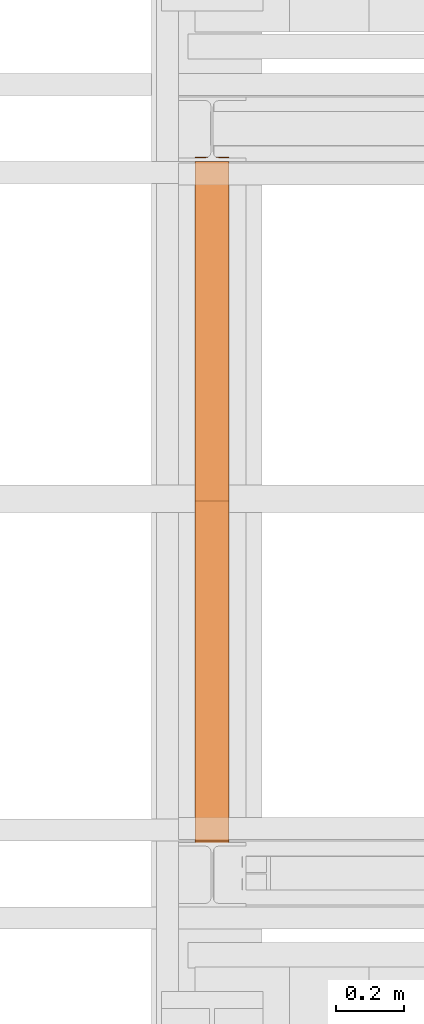
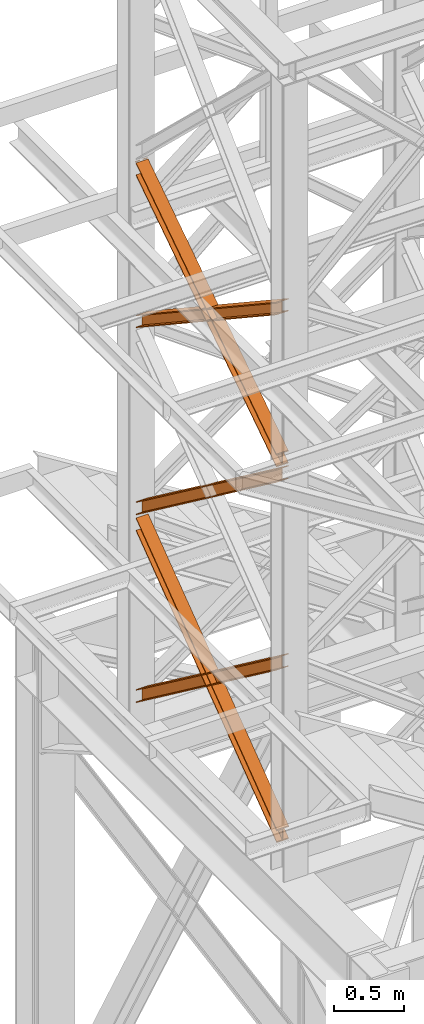
# One storey, part 95 of 208: 5 proxies.
"""IFC2X3 building model written with IfcOpenShell, lengths in millimetres."""

import ifcopenshell
import ifcopenshell.guid

model = None  # the IFC model being written
_history = None  # IfcOwnerHistory: only IFC2X3 demands one
_inside = {}  # id of a spatial element -> (the spatial element, [elements in it])
_under = {}  # id of a project, library or spatial element -> (it, [spatial elements below it])
_declared = {}  # id of a project -> (the project, [libraries it declares])
_typed = {}  # id of a type object -> (the type object, [elements of that type])
_made_of = {}  # id of a material, layer set ... -> (it, [elements and type objects made of it])


def new_model(schema):
    """Start an empty IFC model of exactly this schema.

    Asked for "IFC4X3", IfcOpenShell would pick the latest addendum, in which some entities
    have other attributes; the version numbers below select the first issue.
    IFC2X3 requires an IfcOwnerHistory on every rooted entity: one is made here for all.
    """
    global model, _history
    if schema == "IFC4X3":
        model = ifcopenshell.file(schema_version=(4, 3, 0, 0))
    else:
        model = ifcopenshell.file(schema=schema)
    _inside.clear()
    _under.clear()
    _declared.clear()
    _typed.clear()
    _made_of.clear()
    _history = None
    if model.schema == "IFC2X3":
        org = make("IfcOrganization", Name="unknown")
        user = make(
            "IfcPersonAndOrganization",
            ThePerson=make("IfcPerson", FamilyName="unknown"),
            TheOrganization=org,
        )
        app = make(
            "IfcApplication",
            ApplicationDeveloper=org,
            Version="unknown",
            ApplicationFullName="unknown",
            ApplicationIdentifier="unknown",
        )
        _history = make(
            "IfcOwnerHistory",
            OwningUser=user,
            OwningApplication=app,
            ChangeAction="ADDED",
            CreationDate=0,
        )
    return model


def make(cls, **values):
    """One entity of the class cls with the attributes given. An attribute that is None is left unset."""
    return model.create_entity(
        cls, **{name: value for name, value in values.items() if value is not None}
    )


def entity(cls, *values):
    """Any entity or typed value of the class cls, its attributes in the order of the schema. None: left unset."""
    e = model.create_entity(cls)
    for i, value in enumerate(values):
        if value is not None:
            e[i] = value
    return e


def rooted(cls, **values):
    """An entity with a GlobalId (a new one), such as an element, a storey or a relation."""
    return make(cls, GlobalId=ifcopenshell.guid.new(), OwnerHistory=_history, **values)


def si_unit(unit_type, name, prefix=None):
    """IfcSIUnit, for example si_unit("LENGTHUNIT", "METRE", prefix="MILLI")."""
    return make("IfcSIUnit", UnitType=unit_type, Prefix=prefix, Name=name)


def converted_unit(unit_type, name, factor, base, dimensions=None, offset=None):
    """IfcConversionBasedUnit, such as the inch: factor (a typed value) times the base unit."""
    return make(
        "IfcConversionBasedUnit"
        if offset is None
        else "IfcConversionBasedUnitWithOffset",
        ConversionOffset=offset,
        Dimensions=None
        if dimensions is None
        else entity("IfcDimensionalExponents", *dimensions),
        UnitType=unit_type,
        Name=name,
        ConversionFactor=make(
            "IfcMeasureWithUnit", ValueComponent=factor, UnitComponent=base
        ),
    )


def assignment(units):
    """IfcUnitAssignment: the units of a project."""
    return None if units is None else make("IfcUnitAssignment", Units=units)


def point(xyz):
    """IfcCartesianPoint."""
    return None if xyz is None else make("IfcCartesianPoint", Coordinates=xyz)


def direction(xyz):
    """IfcDirection."""
    return None if xyz is None else make("IfcDirection", DirectionRatios=xyz)


def frame(location, z_axis=None, x_axis=None):
    """IfcAxis2Placement3D, a coordinate frame: its origin and axes. An axis left out is left unset."""
    return make(
        "IfcAxis2Placement3D",
        Location=point(location),
        Axis=direction(z_axis),
        RefDirection=direction(x_axis),
    )


def origin():
    """The frame at (0, 0, 0) with its axes left unset."""
    return frame((0.0, 0.0, 0.0))


def origin_with_axes():
    """The frame at (0, 0, 0) with the z axis (0, 0, 1) and the x axis (1, 0, 0) written out."""
    return frame((0.0, 0.0, 0.0), z_axis=(0.0, 0.0, 1.0), x_axis=(1.0, 0.0, 0.0))


def place(relative_to, where):
    """IfcLocalPlacement: puts the frame where relative to a parent placement (None: the world)."""
    return make(
        "IfcLocalPlacement", PlacementRelTo=relative_to, RelativePlacement=where
    )


def context(
    kind, dimensions, precision=None, world=None, true_north=None, identifier=None
):
    """IfcGeometricRepresentationContext, for example the 3D "Model" context."""
    return make(
        "IfcGeometricRepresentationContext",
        ContextIdentifier=identifier,
        ContextType=kind,
        CoordinateSpaceDimension=dimensions,
        Precision=precision,
        WorldCoordinateSystem=world,
        TrueNorth=true_north,
    )


def subcontext(parent, identifier, kind, view, scale=None):
    """IfcGeometricRepresentationSubContext, for example "Body" below "Model"."""
    return make(
        "IfcGeometricRepresentationSubContext",
        ContextIdentifier=identifier,
        ContextType=kind,
        ParentContext=parent,
        TargetScale=scale,
        TargetView=view,
    )


def project(units=None, contexts=None):
    """IfcProject with its units and contexts."""
    return rooted(
        "IfcProject",
        Name="project",
        RepresentationContexts=contexts,
        UnitsInContext=assignment(units),
    )


def spatial(cls, under=None, at=None, **own):
    """A site, building, storey or space (cls), placed at a placement, below another one or the project."""
    s = rooted(cls, ObjectPlacement=at, **own)
    if under is not None:
        _under.setdefault(under.id(), (under, []))[1].append(s)
    return s


def faces_of(points, faces, orient=None, outer=None):
    """IfcFace entities. A face is a list of loops; a loop is a list of indices into points, from 0.

    orient and outer hold one flag for each loop. By default every Orientation is true, the
    first loop of a face is its IfcFaceOuterBound and the others are IfcFaceBound.
    """
    made = []
    for i, loops in enumerate(faces):
        bounds = []
        for j, loop in enumerate(loops):
            is_outer = j == 0 if outer is None else outer[i][j]
            bounds.append(
                make(
                    "IfcFaceOuterBound" if is_outer else "IfcFaceBound",
                    Bound=make("IfcPolyLoop", Polygon=[points[k] for k in loop]),
                    Orientation=True if orient is None else orient[i][j],
                )
            )
        made.append(make("IfcFace", Bounds=bounds))
    return made


def faceted_brep(points, faces, orient=None, outer=None, voids=None):
    """IfcFacetedBrep: a solid bounded by flat faces; with voids (closed shells), ...WithVoids."""
    shared = [point(p) for p in points]
    hull = make("IfcClosedShell", CfsFaces=faces_of(shared, faces, orient, outer))
    if voids is None:
        return make("IfcFacetedBrep", Outer=hull)
    return make(
        "IfcFacetedBrepWithVoids",
        Outer=hull,
        Voids=[
            make(cls, CfsFaces=faces_of(shared, fs, o, b)) for cls, fs, o, b in voids
        ],
    )


def shape(context_of_items, identifier, shape_type, items):
    """IfcShapeRepresentation: the items that make up one representation, for example the "Body"."""
    return make(
        "IfcShapeRepresentation",
        ContextOfItems=context_of_items,
        RepresentationIdentifier=identifier,
        RepresentationType=shape_type,
        Items=items,
    )


def made_of(thing, what):
    """Note that an element or type object is made of a material, layer set ...; save() writes the relation."""
    if what is not None:
        _made_of.setdefault(what.id(), (what, []))[1].append(thing)
    return thing


def element(
    cls,
    number,
    at=None,
    inside=None,
    cuts=None,
    type_object=None,
    material=None,
    context=None,
    identifier="Body",
    shape_type=None,
    held_by="IfcProductDefinitionShape",
    body=None,
    shapes=None,
    **own,
):
    """One element of the class cls, such as IfcWall. Its Tag is "e" and its number.

    at: its placement. inside: the storey or other place that contains it. cuts: it is an
    opening in that element (IfcRelVoidsElement). A single representation is given by context,
    identifier, shape_type and body (its items); several are given by shapes. held_by: the class
    of the entity that holds the representations. save() writes the other relations.
    """
    e = rooted(cls, Tag="e%d" % number, ObjectPlacement=at, **own)
    if body is not None:
        shapes = [shape(context, identifier, shape_type, body)]
    if shapes is not None:
        e.Representation = make(held_by, Representations=shapes)
    if inside is not None:
        _inside.setdefault(inside.id(), (inside, []))[1].append(e)
    if cuts is not None:
        rooted(
            "IfcRelVoidsElement", RelatingBuildingElement=cuts, RelatedOpeningElement=e
        )
    if type_object is not None:
        _typed.setdefault(type_object.id(), (type_object, []))[1].append(e)
    return made_of(e, material)


def aggregate(whole, parts):
    """IfcRelAggregates: a whole, such as a stair, and the parts it consists of."""
    return rooted("IfcRelAggregates", RelatingObject=whole, RelatedObjects=parts)


def save(model, path):
    """Write the relations noted so far, then the file.

    IfcRelAggregates (storeys below a building ...), IfcRelContainedInSpatialStructure (elements
    in a storey), IfcRelDefinesByType, IfcRelAssociatesMaterial and IfcRelDeclares: one each for
    every whole, place, type object, material and project.
    """
    for whole, parts in _under.values():
        aggregate(whole, parts)
    for where, things in _inside.values():
        rooted(
            "IfcRelContainedInSpatialStructure",
            RelatedElements=things,
            RelatingStructure=where,
        )
    for kind, things in _typed.values():
        rooted("IfcRelDefinesByType", RelatedObjects=things, RelatingType=kind)
    for what, things in _made_of.values():
        rooted("IfcRelAssociatesMaterial", RelatedObjects=things, RelatingMaterial=what)
    for by, libraries in _declared.values():
        rooted("IfcRelDeclares", RelatingContext=by, RelatedDefinitions=libraries)
    model.write(path)


model = new_model("IFC2X3")

# Units and contexts
model_context = context("Model", 3, precision=1e-05, world=origin())
plan_context = context("Plan", 3, precision=1e-05, world=origin())
body_context = subcontext(model_context, "Body", "Model", "MODEL_VIEW")
ifc_project = project(units=[si_unit("LENGTHUNIT", "METRE", prefix="MILLI"), converted_unit("PLANEANGLEUNIT", "DEGREE", entity("IfcPlaneAngleMeasure", 0.0174532925199433), si_unit("PLANEANGLEUNIT", "RADIAN"), dimensions=[0, 0, 0, 0, 0, 0, 0]), si_unit("AREAUNIT", "SQUARE_METRE"), si_unit("VOLUMEUNIT", "CUBIC_METRE")], contexts=[model_context, plan_context])

# Building, storey
building_placement = place(None, origin())
building = spatial("IfcBuilding", under=ifc_project, at=building_placement, CompositionType="COMPLEX")
storey_placement = place(building_placement, origin_with_axes())
storey = spatial("IfcBuildingStorey", under=building, at=storey_placement, Name="Geschoss", CompositionType="ELEMENT")

# Proxies
proxy_1_placement = place(storey_placement, frame((-3357.29171440991, -15867.5743840594, 8785.68637815495), z_axis=(0.0, 0.0, 1.0), x_axis=(1.0, 0.0, 0.0)))
element("IfcBuildingElementProxy", 1, at=proxy_1_placement, inside=storey, context=body_context, shape_type="Brep", body=[
    faceted_brep([(100.0233329519015, 2010.009987483023, 1330.225167941017), (100.1729351296908, 0.00999999999839929, 0.02100513656660041), (100.1718996660056, 0.00999999999839929, 9.435622162609434), (100.0222968606722, 2010.009987483023, 1339.639782821612), (0.0233335574685043, 2010.009987483023, 1330.214162804454), (0.1729357352560328, 0.00999999999839929, 0.01000000000021828), (100.1729351296908, 0.00999999999839929, 0.02100513656660041), (100.0233329519015, 2010.009987483023, 1330.225167941017), (0.02229746624107065, 2010.009987483023, 1339.628777685057), (0.1719002715708484, 0.00999999999839929, 9.424617026043052), (0.1729357352560328, 0.00999999999839929, 0.01000000000021828), (0.0233335574685043, 2010.009987483023, 1330.214162804454), (47.52229717859518, 2010.009987483023, 1339.634005124923), (47.67189998392678, 0.00999999999839929, 9.429844465905262), (0.1719002715708484, 0.00999999999839929, 9.424617026043052), (0.02229746624107065, 2010.009987483023, 1339.628777685057), (47.5119362662881, 2010.009987483023, 1433.780153930935), (47.66154536059003, 0.00999999999839929, 103.5760147725105), (47.67189998392678, 0.00999999999839929, 9.429844465905262), (47.52229717859518, 2010.009987483023, 1339.634005124923), (0.01106478197652905, 2021.979642245309, 1441.696427017001), (0.01120823570636276, 2020.00998539686, 1440.39291091142), (29.30668085241086, 2020.00998539686, 1440.396134918205), (38.62249288135536, 2021.874530444144, 1441.631113415808), (38.72760466098953, 2021.979642245309, 1441.70068782511), (47.5119362662881, 2010.009987483023, 1433.780153930935), (0.01193655393217341, 2010.009987483023, 1433.774926491073), (0.161545648234096, 0.00999999999839929, 103.5707873326446), (47.66154536059003, 0.00999999999839929, 103.5760147725105), (0.01000000000021828, 2022.373573614999, 1451.371745118717), (0.01017214447529113, 2020.00998539686, 1449.807525792019), (0.01120823570636276, 2020.00998539686, 1440.39291091142), (0.01106478197652905, 2021.979642245309, 1441.696427017001), (0.01193655393217341, 2010.009987483023, 1433.774926491073), (0.01090046270292078, 2010.009987483023, 1443.189541371672), (0.1605101872537489, 0.00999999999839929, 112.9854043679352), (0.161545648234096, 0.00999999999839929, 103.5707873326446), (100.0099993944386, 2022.373573614997, 1451.382750255283), (100.0101715389137, 2020.00998539686, 1449.818530928586), (71.806685024736, 2020.00998539686, 1449.815427096359), (62.49087299579151, 2021.874530444144, 1451.048355158282), (61.99182992716487, 2022.373573614999, 1451.378566303787), (0.01090046270292078, 2010.009987483023, 1443.189541371672), (100.0108998571395, 2010.009987483023, 1443.200546508238), (100.1605095816922, 0.00999999999839929, 112.9964095044979), (0.1605101872537489, 0.00999999999839929, 112.9854043679352), (0.01017214447529113, 2020.00998539686, 1449.807525792019), (0.01000000000021828, 2022.373573614999, 1451.371745118717), (39.12153594998017, 2022.373573614999, 1451.376049396686), (38.62249288135536, 2021.874530444144, 1451.045728410436), (29.30668085241086, 2020.00998539686, 1449.810749912833), (100.0110641764131, 2021.979642245307, 1441.707432153557), (100.0112076301411, 2020.00998539686, 1440.403916047975), (100.0101715389137, 2020.00998539686, 1449.818530928586), (100.0099993944386, 2022.373573614997, 1451.382750255283), (100.0108998571395, 2010.009987483023, 1443.200546508238), (100.0119359483706, 2010.009987483023, 1433.785931627628), (100.1615450426671, 0.00999999999839929, 103.5817924692037), (100.1605095816922, 0.00999999999839929, 112.9964095044979), (52.51193623601102, 2010.009987483023, 1433.780704187766), (52.66154533031295, 0.00999999999839929, 103.5765650293379), (100.1615450426671, 0.00999999999839929, 103.5817924692037), (100.0119359483706, 2010.009987483023, 1433.785931627628), (71.806685024736, 2020.00998539686, 1440.400812101727), (100.0112076301411, 2020.00998539686, 1440.403916047975), (100.0110641764131, 2021.979642245307, 1441.707432153557), (62.38576121615733, 2021.979642245309, 1441.703291437565), (62.49087299579151, 2021.874530444144, 1441.63374016365), (52.52229714831447, 2010.009987483023, 1339.63455538175), (52.67189995364788, 0.00999999999839929, 9.43039472273631), (52.66154533031295, 0.00999999999839929, 103.5765650293379), (52.51193623601102, 2010.009987483023, 1433.780704187766), (100.0222968606722, 2010.009987483023, 1339.639782821612), (100.1718996660056, 0.00999999999839929, 9.435622162609434), (52.67189995364788, 0.00999999999839929, 9.43039472273631), (52.52229714831447, 2010.009987483023, 1339.63455538175), (62.38576121615733, 2021.979642245309, 1441.703291437565), (100.0110641764131, 2021.979642245307, 1441.707432153557), (100.0099993944386, 2022.373573614997, 1451.382750255283), (61.99182992716487, 2022.373573614999, 1451.378566303787), (39.12153594998017, 2022.373573614999, 1451.376049396686), (0.01000000000021828, 2022.373573614999, 1451.371745118717), (0.01106478197652905, 2021.979642245309, 1441.696427017001), (38.72760466098953, 2021.979642245309, 1441.70068782511), (62.49087299579151, 2021.874530444144, 1441.63374016365), (62.38576121615733, 2021.979642245309, 1441.703291437565), (61.99182992716487, 2022.373573614999, 1451.378566303787), (62.49087299579151, 2021.874530444144, 1451.048355158282), (62.49087299579151, 2021.874530444144, 1451.048355158282), (71.806685024736, 2020.00998539686, 1449.815427096359), (71.806685024736, 2020.00998539686, 1440.400812101727), (62.49087299579151, 2021.874530444144, 1441.63374016365), (71.806685024736, 2020.00998539686, 1449.815427096359), (100.0101715389137, 2020.00998539686, 1449.818530928586), (100.0112076301411, 2020.00998539686, 1440.403916047975), (71.806685024736, 2020.00998539686, 1440.400812101727), (100.0222968606722, 2010.009987483023, 1339.639782821612), (52.52229714831447, 2010.009987483023, 1339.63455538175), (52.51193623601102, 2010.009987483023, 1433.780704187766), (100.0119359483706, 2010.009987483023, 1433.785931627628), (100.0108998571395, 2010.009987483023, 1443.200546508238), (0.01090046270292078, 2010.009987483023, 1443.189541371672), (0.01193655393217341, 2010.009987483023, 1433.774926491073), (47.5119362662881, 2010.009987483023, 1433.780153930935), (47.52229717859518, 2010.009987483023, 1339.634005124923), (0.02229746624107065, 2010.009987483023, 1339.628777685057), (0.0233335574685043, 2010.009987483023, 1330.214162804454), (100.0233329519015, 2010.009987483023, 1330.225167941017), (29.30668085241086, 2020.00998539686, 1440.396134918205), (0.01120823570636276, 2020.00998539686, 1440.39291091142), (0.01017214447529113, 2020.00998539686, 1449.807525792019), (29.30668085241086, 2020.00998539686, 1449.810749912833), (29.30668085241086, 2020.00998539686, 1449.810749912833), (38.62249288135536, 2021.874530444144, 1451.045728410436), (38.62249288135536, 2021.874530444144, 1441.631113415808), (29.30668085241086, 2020.00998539686, 1440.396134918205), (38.62249288135536, 2021.874530444144, 1451.045728410436), (39.12153594998017, 2022.373573614999, 1451.376049396686), (38.72760466098953, 2021.979642245309, 1441.70068782511), (38.62249288135536, 2021.874530444144, 1441.631113415808), (100.1729351296908, 0.00999999999839929, 0.02100513656660041), (0.1729357352560328, 0.00999999999839929, 0.01000000000021828), (0.1719002715708484, 0.00999999999839929, 9.424617026043052), (47.67189998392678, 0.00999999999839929, 9.429844465905262), (47.66154536059003, 0.00999999999839929, 103.5760147725105), (0.161545648234096, 0.00999999999839929, 103.5707873326446), (0.1605101872537489, 0.00999999999839929, 112.9854043679352), (100.1605095816922, 0.00999999999839929, 112.9964095044979), (100.1615450426671, 0.00999999999839929, 103.5817924692037), (52.66154533031295, 0.00999999999839929, 103.5765650293379), (52.67189995364788, 0.00999999999839929, 9.43039472273631), (100.1718996660056, 0.00999999999839929, 9.435622162609434)], [[[0, 1, 2, 3]], [[4, 5, 6, 7]], [[8, 9, 10, 11]], [[12, 13, 14, 15]], [[16, 17, 18, 19]], [[20, 21, 22, 23, 24]], [[25, 26, 27, 28]], [[29, 30, 31, 32]], [[33, 34, 35, 36]], [[37, 38, 39, 40, 41]], [[42, 43, 44, 45]], [[46, 47, 48, 49, 50]], [[51, 52, 53, 54]], [[55, 56, 57, 58]], [[59, 60, 61, 62]], [[63, 64, 65, 66, 67]], [[68, 69, 70, 71]], [[72, 73, 74, 75]], [[76, 77, 78, 79]], [[80, 81, 82, 83]], [[84, 85, 86, 87]], [[88, 89, 90, 91]], [[92, 93, 94, 95]], [[96, 97, 98, 99, 100, 101, 102, 103, 104, 105, 106, 107]], [[108, 109, 110, 111]], [[112, 113, 114, 115]], [[116, 117, 118, 119]], [[120, 121, 122, 123, 124, 125, 126, 127, 128, 129, 130, 131]]], orient=[[False], [False], [False], [False], [False], [False], [False], [False], [False], [False], [False], [False], [False], [False], [False], [False], [False], [False], [False], [False], [False], [False], [False], [False], [False], [False], [False], [False]]),
])
proxy_2_placement = place(storey_placement, frame((-3357.282239092163, -15867.5743840594, 8785.050753356181), z_axis=(0.0, 0.0, 1.0), x_axis=(1.0, 0.0, 0.0)))
element("IfcBuildingElementProxy", 2, at=proxy_2_placement, inside=storey, context=body_context, shape_type="Brep", body=[
    faceted_brep([(100.0213960296205, 0.01000000000021828, 1340.168495796863), (100.1712583843328, 2010.009987483025, 9.436734304987112), (100.1722939377632, 2010.009987483025, 0.02100513655932446), (100.0224320873658, 0.01000000000021828, 1330.752768748162), (100.0224320873658, 0.01000000000021828, 1330.752768748162), (100.1722939377632, 2010.009987483025, 0.02100513655932446), (0.1722945433284622, 2010.009987483025, 0.01000000000021828), (0.02243269293285266, 0.01000000000021828, 1330.741763611606), (0.02243269293285266, 0.01000000000021828, 1330.741763611606), (0.1722945433284622, 2010.009987483025, 0.01000000000021828), (0.1712589898997976, 2010.009987483025, 9.425729168431644), (0.02139663518937596, 0.01000000000021828, 1340.1574906603), (0.02139663518937596, 0.01000000000021828, 1340.1574906603), (0.1712589898997976, 2010.009987483025, 9.425729168431644), (47.67125870225755, 2010.009987483025, 9.430956608297492), (47.52139634754713, 0.01000000000021828, 1340.162718100166), (47.52139634754713, 0.01000000000021828, 1340.162718100166), (47.67125870225755, 2010.009987483025, 9.430956608297492), (47.66090317872477, 2010.009987483025, 103.5882483377918), (47.51103577010144, 0.01000000000021828, 1434.319988587145), (47.51103577010144, 0.01000000000021828, 1434.319988587145), (47.66090317872477, 2010.009987483025, 103.5882483377918), (0.1609034663688362, 2010.009987483025, 103.583020897926), (0.01103605774551397, 0.01000000000021828, 1434.31476114728), (0.01103605774551397, 0.01000000000021828, 1434.31476114728), (0.1609034663688362, 2010.009987483025, 103.583020897926), (0.1598679150920361, 2010.009987483025, 112.998750075405), (0.01000000000021828, 0.01000000000021828, 1443.730488195981), (0.01000000000021828, 0.01000000000021828, 1443.730488195981), (0.1598679150920361, 2010.009987483025, 112.998750075405), (100.159867309525, 2010.009987483025, 113.0097552119678), (100.009999394435, 0.01000000000021828, 1443.741493332544), (100.009999394435, 0.01000000000021828, 1443.741493332544), (100.159867309525, 2010.009987483025, 113.0097552119678), (100.1609028608018, 2010.009987483025, 103.5940260344851), (100.0110354521785, 0.01000000000021828, 1434.325766283846), (100.0110354521785, 0.01000000000021828, 1434.325766283846), (100.1609028608018, 2010.009987483025, 103.5940260344851), (52.66090314844587, 2010.009987483025, 103.5887985946229), (52.51103573982437, 0.01000000000021828, 1434.320538843973), (52.51103573982437, 0.01000000000021828, 1434.320538843973), (52.66090314844587, 2010.009987483025, 103.5887985946229), (52.67125867197683, 2010.009987483025, 9.431506865121264), (52.52139631726823, 0.01000000000021828, 1340.163268357001), (52.52139631726823, 0.01000000000021828, 1340.163268357001), (52.67125867197683, 2010.009987483025, 9.431506865121264), (100.1712583843328, 2010.009987483025, 9.436734304987112), (100.0213960296205, 0.01000000000021828, 1340.168495796863), (100.0224320873658, 0.01000000000021828, 1330.752768748162), (0.02243269293285266, 0.01000000000021828, 1330.741763611606), (0.02139663518937596, 0.01000000000021828, 1340.1574906603), (47.52139634754713, 0.01000000000021828, 1340.162718100166), (47.51103577010144, 0.01000000000021828, 1434.319988587145), (0.01103605774551397, 0.01000000000021828, 1434.31476114728), (0.01000000000021828, 0.01000000000021828, 1443.730488195981), (100.009999394435, 0.01000000000021828, 1443.741493332544), (100.0110354521785, 0.01000000000021828, 1434.325766283846), (52.51103573982437, 0.01000000000021828, 1434.320538843973), (52.52139631726823, 0.01000000000021828, 1340.163268357001), (100.0213960296205, 0.01000000000021828, 1340.168495796863), (100.1712583843328, 2010.009987483025, 9.436734304987112), (52.67125867197683, 2010.009987483025, 9.431506865121264), (52.66090314844587, 2010.009987483025, 103.5887985946229), (100.1609028608018, 2010.009987483025, 103.5940260344851), (100.159867309525, 2010.009987483025, 113.0097552119678), (0.1598679150920361, 2010.009987483025, 112.998750075405), (0.1609034663688362, 2010.009987483025, 103.583020897926), (47.66090317872477, 2010.009987483025, 103.5882483377918), (47.67125870225755, 2010.009987483025, 9.430956608297492), (0.1712589898997976, 2010.009987483025, 9.425729168431644), (0.1722945433284622, 2010.009987483025, 0.01000000000021828), (100.1722939377632, 2010.009987483025, 0.02100513655932446)], [[[0, 1, 2, 3]], [[4, 5, 6, 7]], [[8, 9, 10, 11]], [[12, 13, 14, 15]], [[16, 17, 18, 19]], [[20, 21, 22, 23]], [[24, 25, 26, 27]], [[28, 29, 30, 31]], [[32, 33, 34, 35]], [[36, 37, 38, 39]], [[40, 41, 42, 43]], [[44, 45, 46, 47]], [[48, 49, 50, 51, 52, 53, 54, 55, 56, 57, 58, 59]], [[60, 61, 62, 63, 64, 65, 66, 67, 68, 69, 70, 71]]], orient=[[False], [False], [False], [False], [False], [False], [False], [False], [False], [False], [False], [False], [False], [False]]),
])
proxy_3_placement = place(storey_placement, frame((-3356.917201508901, -15873.1965123697, 5499.689768811883), z_axis=(0.0, 0.0, 1.0), x_axis=(1.0, 0.0, 0.0)))
element("IfcBuildingElementProxy", 3, at=proxy_3_placement, inside=storey, context=body_context, shape_type="Brep", body=[
    faceted_brep([(100.0229428112289, 2015.632115793322, 1505.703241650141), (100.1858455764686, 1.953628280809426, 0.02100513656296243), (100.1847800613887, 1.791659257409265, 9.702984703128095), (100.0218641931642, 2015.632115793322, 1515.50632986583), (0.02294341679771605, 2015.632115793322, 1505.692236513578), (0.1858461820338562, 1.953628280809426, 0.01000000000021828), (100.1858455764686, 1.953628280809426, 0.02100513656296243), (100.0229428112289, 2015.632115793322, 1505.703241650141), (0.02186479873125791, 2015.632115793322, 1515.495324729271), (0.1847806669538841, 1.791659257407446, 9.691979566568989), (0.1858461820338562, 1.953628280809426, 0.01000000000021828), (0.02294341679771605, 2015.632115793322, 1505.692236513578), (47.52186451108355, 2015.632115793322, 1515.500552169136), (47.68478037930981, 1.791659257407446, 9.697207006434837), (0.1847806669538841, 1.791659257407446, 9.691979566568989), (0.02186479873125791, 2015.632115793322, 1515.495324729271), (47.51107833042624, 2015.632115793322, 1613.531434326045), (47.67412522851737, 0.1719690234003792, 106.517002672068), (47.68478037930981, 1.791659257407446, 9.697207006434837), (47.52186451108355, 2015.632115793322, 1515.500552169136), (0.01107861806849542, 2015.632115793322, 1613.526206886179), (0.174125516157801, 0.1719690234003792, 106.5117752322021), (47.67412522851737, 0.1719690234003792, 106.517002672068), (47.51107833042624, 2015.632115793322, 1613.531434326045), (0.01000000000021828, 2015.632115793322, 1623.329295101868), (0.1730600010778289, 0.01000000000021828, 116.1937547987636), (0.174125516157801, 0.1719690234003792, 106.5117752322021), (0.01107861806849542, 2015.632115793322, 1613.526206886179), (100.0099993944386, 2015.632115793322, 1623.340300238435), (100.1730593955126, 0.01000000000203727, 116.2047599353264), (0.1730600010778289, 0.01000000000021828, 116.1937547987636), (0.01000000000021828, 2015.632115793322, 1623.329295101868), (100.0110780125051, 2015.632115793322, 1613.537212022739), (100.1741249105908, 0.1719690234003792, 106.5227803687612), (100.1730593955126, 0.01000000000203727, 116.2047599353264), (100.0099993944386, 2015.632115793322, 1623.340300238435), (52.51107830014917, 2015.632115793322, 1613.531984582873), (52.67412519823665, 0.1719690234003792, 106.5175529288954), (100.1741249105908, 0.1719690234003792, 106.5227803687612), (100.0110780125051, 2015.632115793322, 1613.537212022739), (52.52186448080829, 2015.632115793322, 1515.501102425964), (52.68478034903274, 1.791659257409265, 9.697757263262247), (52.67412519823665, 0.1719690234003792, 106.5175529288954), (52.51107830014917, 2015.632115793322, 1613.531984582873), (100.0218641931642, 2015.632115793322, 1515.50632986583), (100.1847800613887, 1.791659257409265, 9.702984703128095), (52.68478034903274, 1.791659257409265, 9.697757263262247), (52.52186448080829, 2015.632115793322, 1515.501102425964), (100.1858455764686, 1.953628280809426, 0.02100513656296243), (0.1858461820338562, 1.953628280809426, 0.01000000000021828), (0.1847806669538841, 1.791659257407446, 9.691979566568989), (47.68478037930981, 1.791659257407446, 9.697207006434837), (47.67412522851737, 0.1719690234003792, 106.517002672068), (0.174125516157801, 0.1719690234003792, 106.5117752322021), (0.1730600010778289, 0.01000000000021828, 116.1937547987636), (100.1730593955126, 0.01000000000203727, 116.2047599353264), (100.1741249105908, 0.1719690234003792, 106.5227803687612), (52.67412519823665, 0.1719690234003792, 106.5175529288954), (52.68478034903274, 1.791659257409265, 9.697757263262247), (100.1847800613887, 1.791659257409265, 9.702984703128095), (100.0218641931642, 2015.632115793322, 1515.50632986583), (52.52186448080829, 2015.632115793322, 1515.501102425964), (52.51107830014917, 2015.632115793322, 1613.531984582873), (100.0110780125051, 2015.632115793322, 1613.537212022739), (100.0099993944386, 2015.632115793322, 1623.340300238435), (0.01000000000021828, 2015.632115793322, 1623.329295101868), (0.01107861806849542, 2015.632115793322, 1613.526206886179), (47.51107833042624, 2015.632115793322, 1613.531434326045), (47.52186451108355, 2015.632115793322, 1515.500552169136), (0.02186479873125791, 2015.632115793322, 1515.495324729271), (0.02294341679771605, 2015.632115793322, 1505.692236513578), (100.0229428112289, 2015.632115793322, 1505.703241650141)], [[[0, 1, 2, 3]], [[4, 5, 6, 7]], [[8, 9, 10, 11]], [[12, 13, 14, 15]], [[16, 17, 18, 19]], [[20, 21, 22, 23]], [[24, 25, 26, 27]], [[28, 29, 30, 31]], [[32, 33, 34, 35]], [[36, 37, 38, 39]], [[40, 41, 42, 43]], [[44, 45, 46, 47]], [[48, 49, 50, 51, 52, 53, 54, 55, 56, 57, 58, 59]], [[60, 61, 62, 63, 64, 65, 66, 67, 68, 69, 70, 71]]], orient=[[False], [False], [False], [False], [False], [False], [False], [False], [False], [False], [False], [False], [False], [False]]),
])
proxy_4_placement = place(storey_placement, frame((-3356.917323357426, -15867.5743840594, 5504.219540188055), z_axis=(0.0, 0.0, 1.0), x_axis=(1.0, 0.0, 0.0)))
element("IfcBuildingElementProxy", 4, at=proxy_4_placement, inside=storey, context=body_context, shape_type="Brep", body=[
    faceted_brep([(100.0218596475406, 0.01000000000021828, 1511.076608371926), (100.1844513161013, 2010.009987483025, 9.820176864343011), (100.1855295209298, 2010.009987483025, 0.02100513655932446), (100.0229378523673, 0.01000000000021828, 1501.277436644132), (100.0229378523673, 0.01000000000021828, 1501.277436644132), (100.1855295209298, 2010.009987483025, 0.02100513655932446), (0.1855301264913578, 2010.009987483025, 0.01000000000021828), (0.02293845793246874, 0.01000000000021828, 1501.266431507576), (0.02293845793246874, 0.01000000000021828, 1501.266431507576), (0.1855301264913578, 2010.009987483025, 0.01000000000021828), (0.1844519216665503, 2010.009987483025, 9.809171727787543), (0.02186025310402329, 0.01000000000021828, 1511.06560323536), (0.02186025310402329, 0.01000000000021828, 1511.06560323536), (0.1844519216665503, 2010.009987483025, 9.809171727787543), (47.6844516340243, 2010.009987483025, 9.814399167646116), (47.52185996546359, 0.01000000000021828, 1511.070830675226), (47.52185996546359, 0.01000000000021828, 1511.070830675226), (47.6844516340243, 2010.009987483025, 9.814399167646116), (47.6736695857453, 2010.009987483025, 107.8061164454975), (47.51107791718459, 0.01000000000021828, 1609.062547953077), (47.51107791718459, 0.01000000000021828, 1609.062547953077), (47.6736695857453, 2010.009987483025, 107.8061164454975), (0.1736698733893718, 2010.009987483025, 107.8008890056317), (0.01107820482866373, 0.01000000000021828, 1609.057320513211), (0.01107820482866373, 0.01000000000021828, 1609.057320513211), (0.1736698733893718, 2010.009987483025, 107.8008890056317), (0.1725916685609263, 2010.009987483025, 117.6000607334227), (0.01000000000021828, 0.01000000000021828, 1618.856492240995), (0.01000000000021828, 0.01000000000021828, 1618.856492240995), (0.1725916685609263, 2010.009987483025, 117.6000607334227), (100.1725910629975, 2010.009987483025, 117.6110658699781), (100.009999394435, 0.01000000000021828, 1618.867497377558), (100.009999394435, 0.01000000000021828, 1618.867497377558), (100.1725910629975, 2010.009987483025, 117.6110658699781), (100.1736692678242, 2010.009987483025, 107.8118941421981), (100.0110775992634, 0.01000000000021828, 1609.068325649774), (100.0110775992634, 0.01000000000021828, 1609.068325649774), (100.1736692678242, 2010.009987483025, 107.8118941421981), (52.67366955546459, 2010.009987483025, 107.806666702325), (52.51107788690388, 0.01000000000021828, 1609.063098209905), (52.51107788690388, 0.01000000000021828, 1609.063098209905), (52.67366955546459, 2010.009987483025, 107.806666702325), (52.6844516037454, 2010.009987483025, 9.814949424477163), (52.52185993518287, 0.01000000000021828, 1511.071380932057), (52.52185993518287, 0.01000000000021828, 1511.071380932057), (52.6844516037454, 2010.009987483025, 9.814949424477163), (100.1844513161013, 2010.009987483025, 9.820176864343011), (100.0218596475406, 0.01000000000021828, 1511.076608371926), (100.1844513161013, 2010.009987483025, 9.820176864343011), (52.6844516037454, 2010.009987483025, 9.814949424477163), (52.67366955546459, 2010.009987483025, 107.806666702325), (100.1736692678242, 2010.009987483025, 107.8118941421981), (100.1725910629975, 2010.009987483025, 117.6110658699781), (0.1725916685609263, 2010.009987483025, 117.6000607334227), (0.1736698733893718, 2010.009987483025, 107.8008890056317), (47.6736695857453, 2010.009987483025, 107.8061164454975), (47.6844516340243, 2010.009987483025, 9.814399167646116), (0.1844519216665503, 2010.009987483025, 9.809171727787543), (0.1855301264913578, 2010.009987483025, 0.01000000000021828), (100.1855295209298, 2010.009987483025, 0.02100513655932446), (100.0229378523673, 0.01000000000021828, 1501.277436644132), (0.02293845793246874, 0.01000000000021828, 1501.266431507576), (0.02186025310402329, 0.01000000000021828, 1511.06560323536), (47.52185996546359, 0.01000000000021828, 1511.070830675226), (47.51107791718459, 0.01000000000021828, 1609.062547953077), (0.01107820482866373, 0.01000000000021828, 1609.057320513211), (0.01000000000021828, 0.01000000000021828, 1618.856492240995), (100.009999394435, 0.01000000000021828, 1618.867497377558), (100.0110775992634, 0.01000000000021828, 1609.068325649774), (52.51107788690388, 0.01000000000021828, 1609.063098209905), (52.52185993518287, 0.01000000000021828, 1511.071380932057), (100.0218596475406, 0.01000000000021828, 1511.076608371926)], [[[0, 1, 2, 3]], [[4, 5, 6, 7]], [[8, 9, 10, 11]], [[12, 13, 14, 15]], [[16, 17, 18, 19]], [[20, 21, 22, 23]], [[24, 25, 26, 27]], [[28, 29, 30, 31]], [[32, 33, 34, 35]], [[36, 37, 38, 39]], [[40, 41, 42, 43]], [[44, 45, 46, 47]], [[48, 49, 50, 51, 52, 53, 54, 55, 56, 57, 58, 59]], [[60, 61, 62, 63, 64, 65, 66, 67, 68, 69, 70, 71]]], orient=[[False], [False], [False], [False], [False], [False], [False], [False], [False], [False], [False], [False], [False], [False]]),
])
proxy_5_placement = place(storey_placement, frame((-3357.104524643628, -15867.5743840594, 7147.441290649187), z_axis=(0.0, 0.0, 1.0), x_axis=(1.0, 0.0, 0.0)))
element("IfcBuildingElementProxy", 5, at=proxy_5_placement, inside=storey, context=body_context, shape_type="Brep", body=[
    faceted_brep([(100.0218623025612, 0.01000000000021828, 1512.063556389601), (100.1844166626906, 2010.009987483025, 9.822513400360549), (100.1854951088862, 2010.009987483025, 0.02100513655932446), (100.022940748755, 0.01000000000021828, 1502.262048125804), (100.022940748755, 0.01000000000021828, 1502.262048125804), (100.1854951088862, 2010.009987483025, 0.02100513655932446), (0.1854957144514629, 2010.009987483025, 0.01000000000021828), (0.02294135431839095, 0.01000000000021828, 1502.251042989237), (0.02294135431839095, 0.01000000000021828, 1502.251042989237), (0.1854957144514629, 2010.009987483025, 0.01000000000021828), (0.1844172682558565, 2010.009987483025, 9.811508263797805), (0.02186290812642255, 0.01000000000021828, 1512.052551253039), (0.02186290812642255, 0.01000000000021828, 1512.052551253039), (0.1844172682558565, 2010.009987483025, 9.811508263797805), (47.68441698061361, 2010.009987483025, 9.816735703663653), (47.52186262048235, 0.01000000000021828, 1512.057778692908), (47.52186262048235, 0.01000000000021828, 1512.057778692908), (47.68441698061361, 2010.009987483025, 9.816735703663653), (47.67363251868483, 2010.009987483025, 107.8318183416577), (47.51107815855175, 0.01000000000021828, 1610.072861330906), (47.51107815855175, 0.01000000000021828, 1610.072861330906), (47.67363251868483, 2010.009987483025, 107.8318183416577), (0.1736328063252586, 2010.009987483025, 107.8265909017955), (0.01107844619582465, 0.01000000000021828, 1610.067633891033), (0.01107844619582465, 0.01000000000021828, 1610.067633891033), (0.1736328063252586, 2010.009987483025, 107.8265909017955), (0.1725543601314712, 2010.009987483025, 117.6280991655931), (0.01000000000021828, 0.01000000000021828, 1619.86914215483), (0.01000000000021828, 0.01000000000021828, 1619.86914215483), (0.1725543601314712, 2010.009987483025, 117.6280991655931), (100.1725537545663, 2010.009987483025, 117.6391043021558), (100.009999394435, 0.01000000000021828, 1619.880147291397), (100.009999394435, 0.01000000000021828, 1619.880147291397), (100.1725537545663, 2010.009987483025, 117.6391043021558), (100.1736322007619, 2010.009987483025, 107.8375960383546), (100.0110778406306, 0.01000000000021828, 1610.078639027603), (100.0110778406306, 0.01000000000021828, 1610.078639027603), (100.1736322007619, 2010.009987483025, 107.8375960383546), (52.67363248840411, 2010.009987483025, 107.8323685984888), (52.51107812827468, 0.01000000000021828, 1610.073411587733), (52.51107812827468, 0.01000000000021828, 1610.073411587733), (52.67363248840411, 2010.009987483025, 107.8323685984888), (52.68441695033471, 2010.009987483025, 9.817285960491063), (52.52186259020346, 0.01000000000021828, 1512.058328949732), (52.52186259020346, 0.01000000000021828, 1512.058328949732), (52.68441695033471, 2010.009987483025, 9.817285960491063), (100.1844166626906, 2010.009987483025, 9.822513400360549), (100.0218623025612, 0.01000000000021828, 1512.063556389601), (100.1844166626906, 2010.009987483025, 9.822513400360549), (52.68441695033471, 2010.009987483025, 9.817285960491063), (52.67363248840411, 2010.009987483025, 107.8323685984888), (100.1736322007619, 2010.009987483025, 107.8375960383546), (100.1725537545663, 2010.009987483025, 117.6391043021558), (0.1725543601314712, 2010.009987483025, 117.6280991655931), (0.1736328063252586, 2010.009987483025, 107.8265909017955), (47.67363251868483, 2010.009987483025, 107.8318183416577), (47.68441698061361, 2010.009987483025, 9.816735703663653), (0.1844172682558565, 2010.009987483025, 9.811508263797805), (0.1854957144514629, 2010.009987483025, 0.01000000000021828), (100.1854951088862, 2010.009987483025, 0.02100513655932446), (100.022940748755, 0.01000000000021828, 1502.262048125804), (0.02294135431839095, 0.01000000000021828, 1502.251042989237), (0.02186290812642255, 0.01000000000021828, 1512.052551253039), (47.52186262048235, 0.01000000000021828, 1512.057778692908), (47.51107815855175, 0.01000000000021828, 1610.072861330906), (0.01107844619582465, 0.01000000000021828, 1610.067633891033), (0.01000000000021828, 0.01000000000021828, 1619.86914215483), (100.009999394435, 0.01000000000021828, 1619.880147291397), (100.0110778406306, 0.01000000000021828, 1610.078639027603), (52.51107812827468, 0.01000000000021828, 1610.073411587733), (52.52186259020346, 0.01000000000021828, 1512.058328949732), (100.0218623025612, 0.01000000000021828, 1512.063556389601)], [[[0, 1, 2, 3]], [[4, 5, 6, 7]], [[8, 9, 10, 11]], [[12, 13, 14, 15]], [[16, 17, 18, 19]], [[20, 21, 22, 23]], [[24, 25, 26, 27]], [[28, 29, 30, 31]], [[32, 33, 34, 35]], [[36, 37, 38, 39]], [[40, 41, 42, 43]], [[44, 45, 46, 47]], [[48, 49, 50, 51, 52, 53, 54, 55, 56, 57, 58, 59]], [[60, 61, 62, 63, 64, 65, 66, 67, 68, 69, 70, 71]]], orient=[[False], [False], [False], [False], [False], [False], [False], [False], [False], [False], [False], [False], [False], [False]]),
])

save(model, "model.ifc")
